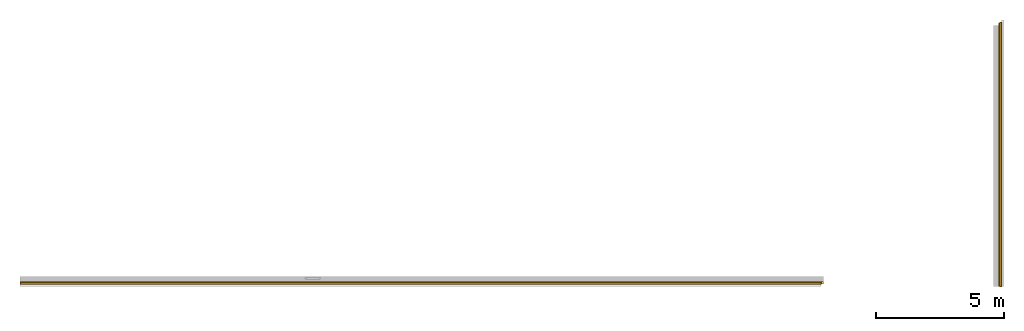
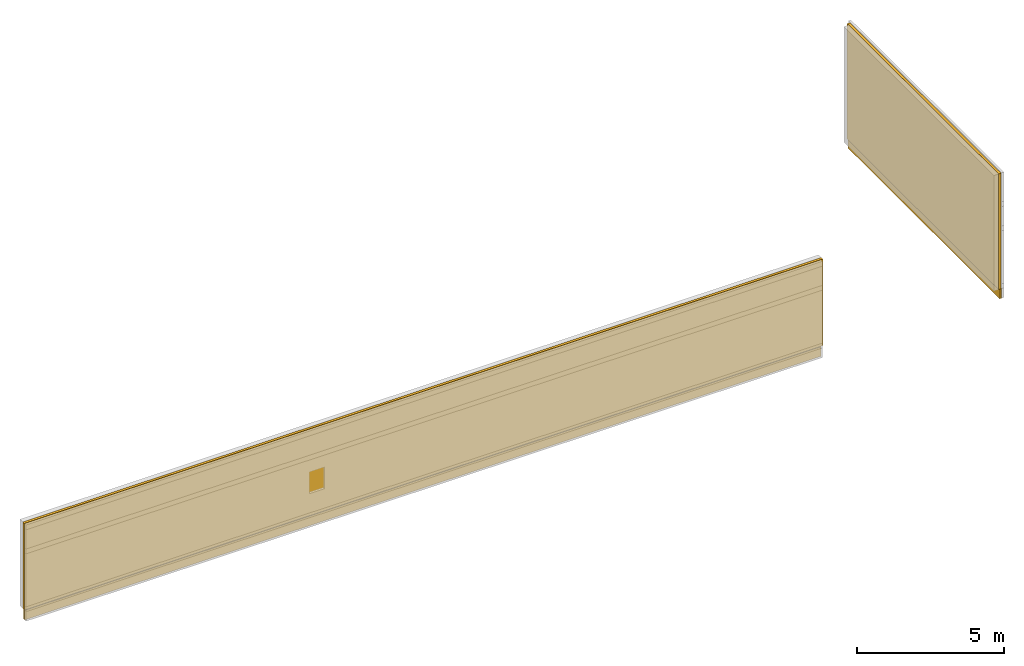
# One storey, part 2 of 2: 4 coverings.
"""IFC4X3_ADD2 building model written with IfcOpenShell, lengths in millimetres."""

from ifc_helpers import new_model, entity, si_unit, converted_unit, frame, origin_with_axes, origin_2d_with_axis, place, context, subcontext, project, spatial, indexed_curve, outline, extrude, material, layer, layer_set, layer_usage, type_object, element, save


model = new_model("IFC4X3_ADD2")

# Units and contexts
model_context = context("Model", 3, precision=1e-05, world=origin_with_axes())
plan_context = context("Plan", 2, precision=1e-05, world=origin_2d_with_axis())
body_context = subcontext(model_context, "Body", "Model", "MODEL_VIEW")
ifc_project = project(units=[converted_unit("PLANEANGLEUNIT", "degree", entity("IfcReal", 0.0174532925199433), si_unit("PLANEANGLEUNIT", "RADIAN"), dimensions=[0, 0, 0, 0, 0, 0, 0]), si_unit("AREAUNIT", "SQUARE_METRE", prefix="MILLI"), si_unit("VOLUMEUNIT", "CUBIC_METRE", prefix="MILLI"), si_unit("LENGTHUNIT", "METRE", prefix="MILLI")], contexts=[model_context, plan_context])

# Site, building, storey
site_placement = place(None, frame((0.0, 0.0, -200.000002980232), z_axis=(0.0, 0.0, 1.0), x_axis=(1.0, 0.0, 0.0)))
site = spatial("IfcSite", under=ifc_project, at=site_placement)
building_placement = place(site_placement, frame((0.0, 0.0, 200.000002980232), z_axis=(0.0, 0.0, 1.0), x_axis=(1.0, 0.0, 0.0)))
building = spatial("IfcBuilding", under=site, at=building_placement, Name="001")
storey_placement = place(building_placement, origin_with_axes())
storey = spatial("IfcBuildingStorey", under=building, at=storey_placement, Name="001 - TOP OF FIN. FLOOR")

# Coverings
ifc_material_1 = material(Name="Rigid Insulation", Category="07211 - Rigid Insulation")
ifc_layer_1 = layer(ifc_material_1, 75.0, Name="Vertical Insulation")
ifc_layer_set_1 = layer_set([ifc_layer_1])
ifc_layer_usage_1 = layer_usage(ifc_layer_set_1, "AXIS2", "POSITIVE", 0.0)
covering_type_1 = type_object("IfcCoveringType", Name="Foundation Wall Insulation - 75", PredefinedType="INSULATION", material=ifc_layer_set_1)
covering_1_placement = place(storey_placement, frame((3198.99368286133, -3018.05853843689, -400.000005960464), z_axis=(0.0, 0.0, 1.0), x_axis=(1.0, 0.0, 0.0)))
element("IfcCovering", 1, at=covering_1_placement, inside=storey, type_object=covering_type_1, material=ifc_layer_usage_1, Name="BuildingElementPart.016", PredefinedType="INSULATION", context=body_context, shape_type="SweptSolid", body=[
    extrude(outline(indexed_curve([(0.0, 0.0), (0.0, 75.0), (31275.8067270179, 75.0), (31275.8067270179, 0.0), (0.0, 0.0)], self_intersect=False)), origin_with_axes(), (0.0, 0.0, 1.0), 400.000005960464),
])
ifc_layer_usage_2 = layer_usage(ifc_layer_set_1, "AXIS2", "POSITIVE", 0.0)
covering_2_placement = place(storey_placement, frame((41525.1388549805, -3107.6967716217, -400.000005960464), z_axis=(0.0, 0.0, 1.0), x_axis=(3.13916473260163e-07, 0.999999999999951, 0.0)))
element("IfcCovering", 2, at=covering_2_placement, inside=storey, type_object=covering_type_1, material=ifc_layer_usage_2, Name="BuildingElementPart.001", PredefinedType="INSULATION", context=body_context, shape_type="SweptSolid", body=[
    extrude(outline(indexed_curve([(0.0, 0.0), (0.0, 75.0), (10320.3638784449, 75.0), (10320.3638784449, 0.0), (0.0, 0.0)], self_intersect=False)), origin_with_axes(), (0.0, 0.0, 1.0), 400.000005960464),
])
ifc_material_2 = material(Name="Spray Foam", Category="07215 - on Insulation")
ifc_layer_2 = layer(ifc_material_2, 100.0, Name="Spray Foam", Category="Insulation")
ifc_layer_set_2 = layer_set([ifc_layer_2])
ifc_layer_usage_3 = layer_usage(ifc_layer_set_2, "AXIS2", "POSITIVE", 0.0)
covering_type_2 = type_object("IfcCoveringType", PredefinedType="INSULATION", material=ifc_layer_set_2)
covering_3_placement = place(storey_placement, frame((41404.78515625, 7191.94650650024, 0.0), z_axis=(0.0, 0.0, 1.0), x_axis=(-6.39757843145941e-07, -0.999999999999795, 0.0)))
element("IfcCovering", 3, at=covering_3_placement, inside=storey, type_object=covering_type_2, material=ifc_layer_usage_3, Name="Covering", context=body_context, shape_type="SweptSolid", body=[
    extrude(outline(indexed_curve([(0.0, 0.0), (0.0, 100.0), (10299.6435307446, 100.0), (10299.6435307446, 0.0), (0.0, 0.0)], self_intersect=False)), origin_with_axes(), (0.0, 0.0, 1.0), 4800.00019073486),
])
ifc_layer_usage_4 = layer_usage(ifc_layer_set_2, "AXIS2", "POSITIVE", 0.0)
covering_4_placement = place(storey_placement, frame((34561.9964599609, -2897.70364761353, 0.0), z_axis=(0.0, 0.0, 1.0), x_axis=(-0.999999999999924, 3.89414367418765e-07, 0.0)))
element("IfcCovering", 4, at=covering_4_placement, inside=storey, type_object=covering_type_2, material=ifc_layer_usage_4, Name="Covering", context=body_context, shape_type="SweptSolid", body=[
    extrude(outline(indexed_curve([(0.0, 0.0), (0.0, 100.0), (31362.9783913195, 100.0), (31362.9783913195, 0.0), (0.0, 0.0)], self_intersect=False)), origin_with_axes(), (0.0, 0.0, 1.0), 3600.00014305115),
])

save(model, "model.ifc")
